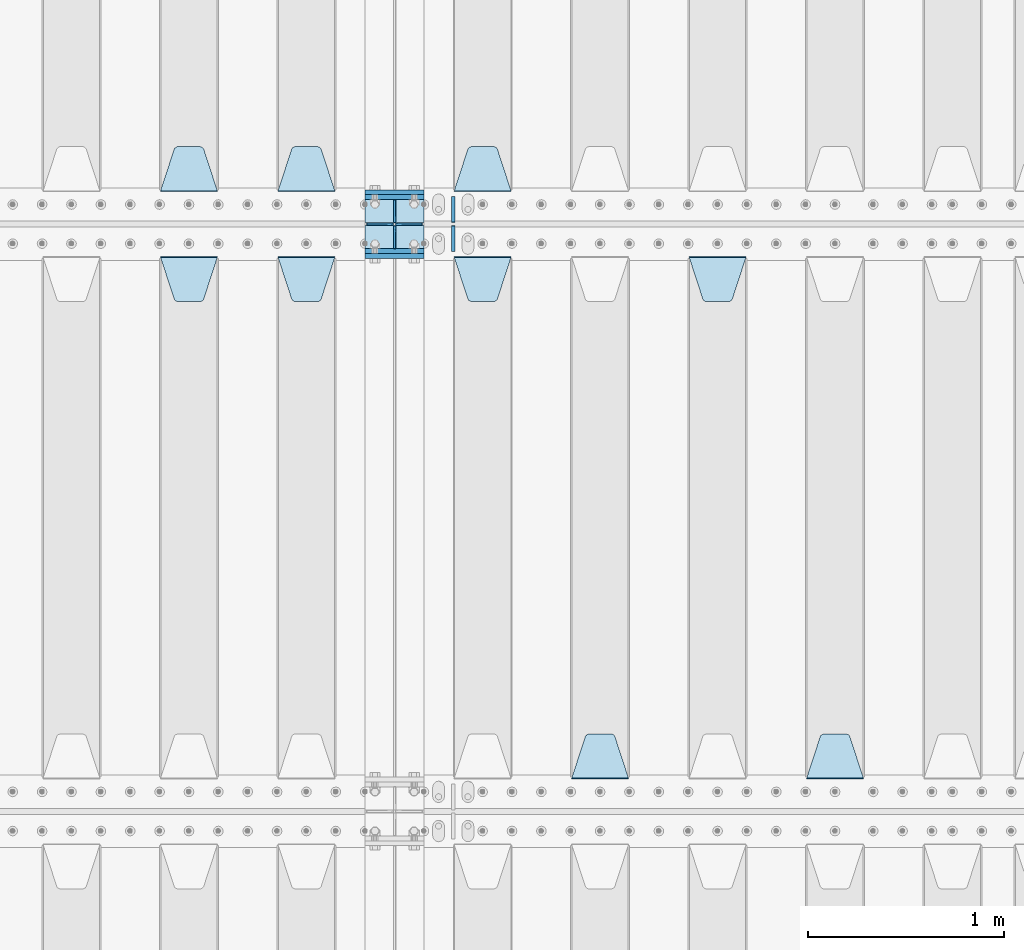
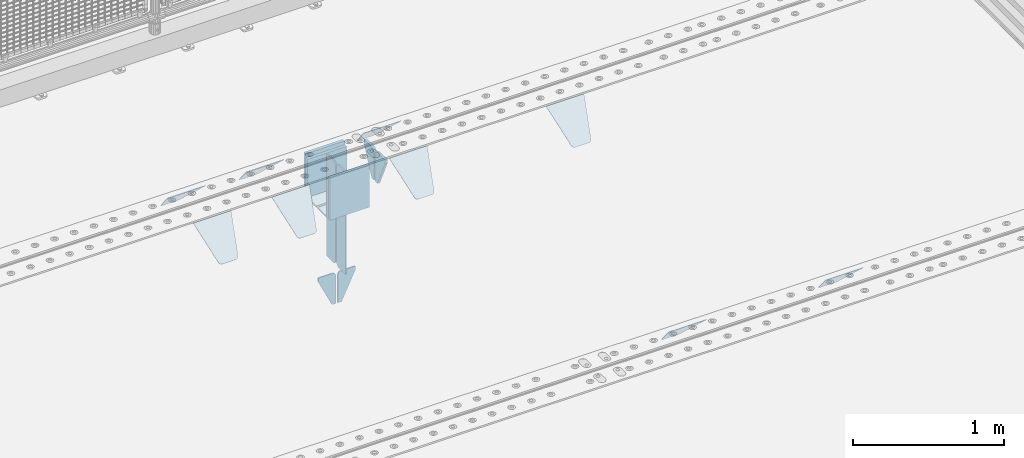
# One storey, part 210 of 247: 23 plates.
"""IFC2X3 building model written with IfcOpenShell, lengths in millimetres."""

import ifcopenshell
import ifcopenshell.guid

model = None  # the IFC model being written
_history = None  # IfcOwnerHistory: only IFC2X3 demands one
_inside = {}  # id of a spatial element -> (the spatial element, [elements in it])
_under = {}  # id of a project, library or spatial element -> (it, [spatial elements below it])
_declared = {}  # id of a project -> (the project, [libraries it declares])
_typed = {}  # id of a type object -> (the type object, [elements of that type])
_made_of = {}  # id of a material, layer set ... -> (it, [elements and type objects made of it])


def new_model(schema):
    """Start an empty IFC model of exactly this schema.

    Asked for "IFC4X3", IfcOpenShell would pick the latest addendum, in which some entities
    have other attributes; the version numbers below select the first issue.
    IFC2X3 requires an IfcOwnerHistory on every rooted entity: one is made here for all.
    """
    global model, _history
    if schema == "IFC4X3":
        model = ifcopenshell.file(schema_version=(4, 3, 0, 0))
    else:
        model = ifcopenshell.file(schema=schema)
    _inside.clear()
    _under.clear()
    _declared.clear()
    _typed.clear()
    _made_of.clear()
    _history = None
    if model.schema == "IFC2X3":
        org = make("IfcOrganization", Name="unknown")
        user = make(
            "IfcPersonAndOrganization",
            ThePerson=make("IfcPerson", FamilyName="unknown"),
            TheOrganization=org,
        )
        app = make(
            "IfcApplication",
            ApplicationDeveloper=org,
            Version="unknown",
            ApplicationFullName="unknown",
            ApplicationIdentifier="unknown",
        )
        _history = make(
            "IfcOwnerHistory",
            OwningUser=user,
            OwningApplication=app,
            ChangeAction="ADDED",
            CreationDate=0,
        )
    return model


def make(cls, **values):
    """One entity of the class cls with the attributes given. An attribute that is None is left unset."""
    return model.create_entity(
        cls, **{name: value for name, value in values.items() if value is not None}
    )


def rooted(cls, **values):
    """An entity with a GlobalId (a new one), such as an element, a storey or a relation."""
    return make(cls, GlobalId=ifcopenshell.guid.new(), OwnerHistory=_history, **values)


def si_unit(unit_type, name, prefix=None):
    """IfcSIUnit, for example si_unit("LENGTHUNIT", "METRE", prefix="MILLI")."""
    return make("IfcSIUnit", UnitType=unit_type, Prefix=prefix, Name=name)


def assignment(units):
    """IfcUnitAssignment: the units of a project."""
    return None if units is None else make("IfcUnitAssignment", Units=units)


def point(xyz):
    """IfcCartesianPoint."""
    return None if xyz is None else make("IfcCartesianPoint", Coordinates=xyz)


def direction(xyz):
    """IfcDirection."""
    return None if xyz is None else make("IfcDirection", DirectionRatios=xyz)


def frame(location, z_axis=None, x_axis=None):
    """IfcAxis2Placement3D, a coordinate frame: its origin and axes. An axis left out is left unset."""
    return make(
        "IfcAxis2Placement3D",
        Location=point(location),
        Axis=direction(z_axis),
        RefDirection=direction(x_axis),
    )


def origin_with_axes():
    """The frame at (0, 0, 0) with the z axis (0, 0, 1) and the x axis (1, 0, 0) written out."""
    return frame((0.0, 0.0, 0.0), z_axis=(0.0, 0.0, 1.0), x_axis=(1.0, 0.0, 0.0))


def place(relative_to, where):
    """IfcLocalPlacement: puts the frame where relative to a parent placement (None: the world)."""
    return make(
        "IfcLocalPlacement", PlacementRelTo=relative_to, RelativePlacement=where
    )


def context(
    kind, dimensions, precision=None, world=None, true_north=None, identifier=None
):
    """IfcGeometricRepresentationContext, for example the 3D "Model" context."""
    return make(
        "IfcGeometricRepresentationContext",
        ContextIdentifier=identifier,
        ContextType=kind,
        CoordinateSpaceDimension=dimensions,
        Precision=precision,
        WorldCoordinateSystem=world,
        TrueNorth=true_north,
    )


def subcontext(parent, identifier, kind, view, scale=None):
    """IfcGeometricRepresentationSubContext, for example "Body" below "Model"."""
    return make(
        "IfcGeometricRepresentationSubContext",
        ContextIdentifier=identifier,
        ContextType=kind,
        ParentContext=parent,
        TargetScale=scale,
        TargetView=view,
    )


def project(units=None, contexts=None):
    """IfcProject with its units and contexts."""
    return rooted(
        "IfcProject",
        Name="project",
        RepresentationContexts=contexts,
        UnitsInContext=assignment(units),
    )


def spatial(cls, under=None, at=None, **own):
    """A site, building, storey or space (cls), placed at a placement, below another one or the project."""
    s = rooted(cls, ObjectPlacement=at, **own)
    if under is not None:
        _under.setdefault(under.id(), (under, []))[1].append(s)
    return s


def faces_of(points, faces, orient=None, outer=None):
    """IfcFace entities. A face is a list of loops; a loop is a list of indices into points, from 0.

    orient and outer hold one flag for each loop. By default every Orientation is true, the
    first loop of a face is its IfcFaceOuterBound and the others are IfcFaceBound.
    """
    made = []
    for i, loops in enumerate(faces):
        bounds = []
        for j, loop in enumerate(loops):
            is_outer = j == 0 if outer is None else outer[i][j]
            bounds.append(
                make(
                    "IfcFaceOuterBound" if is_outer else "IfcFaceBound",
                    Bound=make("IfcPolyLoop", Polygon=[points[k] for k in loop]),
                    Orientation=True if orient is None else orient[i][j],
                )
            )
        made.append(make("IfcFace", Bounds=bounds))
    return made


def faceted_brep(points, faces, orient=None, outer=None, voids=None):
    """IfcFacetedBrep: a solid bounded by flat faces; with voids (closed shells), ...WithVoids."""
    shared = [point(p) for p in points]
    hull = make("IfcClosedShell", CfsFaces=faces_of(shared, faces, orient, outer))
    if voids is None:
        return make("IfcFacetedBrep", Outer=hull)
    return make(
        "IfcFacetedBrepWithVoids",
        Outer=hull,
        Voids=[
            make(cls, CfsFaces=faces_of(shared, fs, o, b)) for cls, fs, o, b in voids
        ],
    )


def shape(context_of_items, identifier, shape_type, items):
    """IfcShapeRepresentation: the items that make up one representation, for example the "Body"."""
    return make(
        "IfcShapeRepresentation",
        ContextOfItems=context_of_items,
        RepresentationIdentifier=identifier,
        RepresentationType=shape_type,
        Items=items,
    )


def material(Name=None, Category=None):
    """IfcMaterial."""
    return make("IfcMaterial", Name=Name, Category=Category)


def made_of(thing, what):
    """Note that an element or type object is made of a material, layer set ...; save() writes the relation."""
    if what is not None:
        _made_of.setdefault(what.id(), (what, []))[1].append(thing)
    return thing


def type_object(cls, material=None, **own):
    """A type object (cls), such as IfcWallType, which elements share."""
    return made_of(rooted(cls, **own), material)


def element(
    cls,
    number,
    at=None,
    inside=None,
    cuts=None,
    type_object=None,
    material=None,
    context=None,
    identifier="Body",
    shape_type=None,
    held_by="IfcProductDefinitionShape",
    body=None,
    shapes=None,
    **own,
):
    """One element of the class cls, such as IfcWall. Its Tag is "e" and its number.

    at: its placement. inside: the storey or other place that contains it. cuts: it is an
    opening in that element (IfcRelVoidsElement). A single representation is given by context,
    identifier, shape_type and body (its items); several are given by shapes. held_by: the class
    of the entity that holds the representations. save() writes the other relations.
    """
    e = rooted(cls, Tag="e%d" % number, ObjectPlacement=at, **own)
    if body is not None:
        shapes = [shape(context, identifier, shape_type, body)]
    if shapes is not None:
        e.Representation = make(held_by, Representations=shapes)
    if inside is not None:
        _inside.setdefault(inside.id(), (inside, []))[1].append(e)
    if cuts is not None:
        rooted(
            "IfcRelVoidsElement", RelatingBuildingElement=cuts, RelatedOpeningElement=e
        )
    if type_object is not None:
        _typed.setdefault(type_object.id(), (type_object, []))[1].append(e)
    return made_of(e, material)


def aggregate(whole, parts):
    """IfcRelAggregates: a whole, such as a stair, and the parts it consists of."""
    return rooted("IfcRelAggregates", RelatingObject=whole, RelatedObjects=parts)


def save(model, path):
    """Write the relations noted so far, then the file.

    IfcRelAggregates (storeys below a building ...), IfcRelContainedInSpatialStructure (elements
    in a storey), IfcRelDefinesByType, IfcRelAssociatesMaterial and IfcRelDeclares: one each for
    every whole, place, type object, material and project.
    """
    for whole, parts in _under.values():
        aggregate(whole, parts)
    for where, things in _inside.values():
        rooted(
            "IfcRelContainedInSpatialStructure",
            RelatedElements=things,
            RelatingStructure=where,
        )
    for kind, things in _typed.values():
        rooted("IfcRelDefinesByType", RelatedObjects=things, RelatingType=kind)
    for what, things in _made_of.values():
        rooted("IfcRelAssociatesMaterial", RelatedObjects=things, RelatingMaterial=what)
    for by, libraries in _declared.values():
        rooted("IfcRelDeclares", RelatingContext=by, RelatedDefinitions=libraries)
    model.write(path)


model = new_model("IFC2X3")

# Units and contexts
model_context = context("Model", 3, precision=1e-05, world=origin_with_axes())
body_context = subcontext(model_context, "Body", "Model", "MODEL_VIEW")
ifc_project = project(units=[si_unit("LENGTHUNIT", "METRE", prefix="MILLI"), si_unit("AREAUNIT", "SQUARE_METRE"), si_unit("VOLUMEUNIT", "CUBIC_METRE"), si_unit("MASSUNIT", "GRAM", prefix="KILO"), si_unit("TIMEUNIT", "SECOND"), si_unit("PLANEANGLEUNIT", "RADIAN"), si_unit("SOLIDANGLEUNIT", "STERADIAN"), si_unit("THERMODYNAMICTEMPERATUREUNIT", "DEGREE_CELSIUS"), si_unit("LUMINOUSINTENSITYUNIT", "LUMEN")], contexts=[model_context])

# Site, building, storey
site_placement = place(None, origin_with_axes())
site = spatial("IfcSite", under=ifc_project, at=site_placement, CompositionType="ELEMENT")
building_placement = place(site_placement, origin_with_axes())
building = spatial("IfcBuilding", under=site, at=building_placement, Name="Standard", CompositionType="ELEMENT")
storey_placement = place(building_placement, origin_with_axes())
storey = spatial("IfcBuildingStorey", under=building, at=storey_placement, Name="Undefined", CompositionType="ELEMENT", Elevation=0.0)

# Plates
ifc_material = material(Name="STEEL/S355N")
plate_type_1 = type_object("IfcPlateType", PredefinedType="NOTDEFINED")
for number, where, z_axis, x_axis in (
    (1, (12100.0, 6162.5, -340.000000000044), (0.0, 0.0, 1.0), (1.0, 0.0, 0.0)),
    (2, (12100.0, 5837.5, -340.000000000044), (0.0, 0.0, 1.0), (1.0, 0.0, 0.0)),
):
    element("IfcPlate", number, at=place(storey_placement, frame(where, z_axis=z_axis, x_axis=x_axis)), inside=storey, type_object=plate_type_1, material=ifc_material, context=body_context, shape_type="Brep", body=[
        faceted_brep([(0.0, -12.5, 0.0), (0.0, -12.5, 340.0), (0.0, 12.5, 340.0), (0.0, 12.5, 0.0), (300.0, -12.5, 340.0), (300.0, 12.5, 340.0), (300.0, -12.5, 0.0), (300.0, 12.5, 0.0)], [[[0, 1, 2, 3]], [[1, 4, 5, 2]], [[4, 6, 7, 5]], [[6, 0, 3, 7]], [[5, 7, 3, 2]], [[6, 4, 1, 0]]]),
    ])
for number, where, z_axis, x_axis in (
    (3, (12100.0, 6137.5, -340.0), (0.0, 0.0, 1.0), (1.0, 0.0, 0.0)),
    (4, (12100.0, 5862.5, -340.0), (0.0, 0.0, 1.0), (1.0, 0.0, 0.0)),
):
    element("IfcPlate", number, at=place(storey_placement, frame(where, z_axis=z_axis, x_axis=x_axis)), inside=storey, type_object=plate_type_1, material=ifc_material, context=body_context, shape_type="Brep", body=[
        faceted_brep([(0.0, -12.5, 0.0), (0.0, -12.5, 310.0), (0.0, 12.5, 310.0), (0.0, 12.5, 0.0), (300.0, -12.5, 310.0), (300.0, 12.5, 310.0), (300.0, -12.5, 0.0), (300.0, 12.5, 0.0)], [[[0, 1, 2, 3]], [[1, 4, 5, 2]], [[4, 6, 7, 5]], [[6, 0, 3, 7]], [[5, 7, 3, 2]], [[6, 4, 1, 0]]]),
    ])
plate_type_2 = type_object("IfcPlateType", PredefinedType="NOTDEFINED")
for number, where, z_axis, x_axis in (
    (5, (12100.0, 5992.0, -343.0), (0.0, -0.999999999999548, -9.5100000000016e-07), (1.0, 0.0, 0.0)),
    (6, (12100.0, 6008.0, -343.0), (0.0, 1.0, 0.0), (1.0, 0.0, 0.0)),
):
    element("IfcPlate", number, at=place(storey_placement, frame(where, z_axis=z_axis, x_axis=x_axis)), inside=storey, type_object=plate_type_2, material=ifc_material, context=body_context, shape_type="Brep", body=[
        faceted_brep([(0.0, -7.0, 0.0), (0.0, -7.0, 117.0), (0.0, 7.0, 117.0), (0.0, 7.0, 0.0), (300.0, -7.0, 117.0), (300.0, 7.0, 117.0), (300.0, -7.0, 0.0), (300.0, 7.0, 0.0)], [[[0, 1, 2, 3]], [[1, 4, 5, 2]], [[4, 6, 7, 5]], [[6, 0, 3, 7]], [[5, 7, 3, 2]], [[6, 4, 1, 0]]]),
    ])
plate_type_3 = type_object("IfcPlateType", PredefinedType="NOTDEFINED")
for number, where, z_axis, x_axis in (
    (7, (12250.0, 5992.0, -350.0), (0.0, 0.0, -1.0), (0.0, -0.999999999999548, -9.5100000000016e-07)),
    (8, (12250.0, 6008.0, -350.0), (0.0, 0.0, -1.0), (0.0, 1.0, 0.0)),
):
    element("IfcPlate", number, at=place(storey_placement, frame(where, z_axis=z_axis, x_axis=x_axis)), inside=storey, type_object=plate_type_3, material=ifc_material, context=body_context, shape_type="Brep", body=[
        faceted_brep([(9.04219632502645e-09, -5.00000000143385, -2.89173840428703e-09), (0.0, -5.0, 480.0), (0.0, 5.0, 480.0), (7.66340235713869e-09, 4.99999999856618, -2.89173840428703e-09), (0.455767409633609, -5.0, 485.209445330008), (0.455767409633609, 5.0, 485.209445330008), (1.80922137642256, -5.0, 490.26060429977), (1.80922137642256, 5.0, 490.26060429977), (4.01923788646673, -5.0, 495.0), (4.01923788646673, 5.0, 495.0), (7.01866670643085, -5.0, 499.283628290596), (7.01866670643085, 5.0, 499.283628290596), (10.716371709404, -5.0, 502.981333293569), (10.716371709404, 5.0, 502.981333293569), (15.0, -5.0, 505.980762113533), (15.0, 5.0, 505.980762113533), (19.73939570023, -5.0, 508.190778623577), (19.73939570023, 5.0, 508.190778623577), (24.7905546699922, -5.0, 509.544232590366), (24.7905546699922, 5.0, 509.544232590366), (30.0, -5.0, 510.0), (30.0, 5.0, 510.0), (117.0, -5.0, 510.0), (117.0, 5.0, 510.0), (117.0, -5.0, 0.0), (117.0, 5.0, 0.0)], [[[0, 1, 2, 3]], [[1, 4, 5, 2]], [[4, 6, 7, 5]], [[6, 8, 9, 7]], [[8, 10, 11, 9]], [[10, 12, 13, 11]], [[12, 14, 15, 13]], [[14, 16, 17, 15]], [[16, 18, 19, 17]], [[18, 20, 21, 19]], [[20, 22, 23, 21]], [[22, 24, 25, 23]], [[24, 0, 3, 25]], [[5, 7, 9, 11, 13, 15, 17, 19, 21, 23, 25, 3, 2]], [[24, 22, 20, 18, 16, 14, 12, 10, 8, 6, 4, 1, 0]]]),
    ])
for number, where, z_axis, x_axis in (
    (9, (12250.0, 6008.0, -30.0), (0.0, 0.0, -1.0), (0.0, 1.0, 0.0)),
    (10, (12250.0, 5992.0, -30.0), (0.0, 0.0, -1.0), (0.0, -0.999999999999548, -9.5100000000016e-07)),
):
    element("IfcPlate", number, at=place(storey_placement, frame(where, z_axis=z_axis, x_axis=x_axis)), inside=storey, type_object=plate_type_3, material=ifc_material, context=body_context, shape_type="Brep", body=[
        faceted_brep([(0.0, -5.0, 30.0), (0.0, -5.0, 306.0), (0.0, 5.0, 306.0), (0.0, 5.0, 30.0), (117.0, -5.0, 306.0), (117.0, 5.0, 306.0), (117.0, -5.0, 0.0), (117.0, 5.0, 0.0), (30.0, -5.0, 0.0), (30.0, 5.0, 0.0), (24.7905546699922, -5.0, 0.455767409633758), (24.7905546699922, 5.0, 0.455767409633758), (19.73939570023, -5.0, 1.80922137642275), (19.73939570023, 5.0, 1.80922137642275), (15.0, -5.0, 4.01923788646684), (15.0, 5.0, 4.01923788646684), (10.716371709404, -5.0, 7.01866670643066), (10.716371709404, 5.0, 7.01866670643066), (7.01866670643085, -5.0, 10.7163717094038), (7.01866670643085, 5.0, 10.7163717094038), (4.01923788646673, -5.0, 15.0), (4.01923788646673, 5.0, 15.0), (1.80922137642256, -5.0, 19.7393957002299), (1.80922137642256, 5.0, 19.7393957002299), (0.455767409633609, -5.0, 24.7905546699921), (0.455767409633609, 5.0, 24.7905546699921)], [[[0, 1, 2, 3]], [[1, 4, 5, 2]], [[4, 6, 7, 5]], [[6, 8, 9, 7]], [[8, 10, 11, 9]], [[10, 12, 13, 11]], [[12, 14, 15, 13]], [[14, 16, 17, 15]], [[16, 18, 19, 17]], [[18, 20, 21, 19]], [[20, 22, 23, 21]], [[22, 24, 25, 23]], [[24, 0, 3, 25]], [[5, 7, 9, 11, 13, 15, 17, 19, 21, 23, 25, 3, 2]], [[24, 22, 20, 18, 16, 14, 12, 10, 8, 6, 4, 1, 0]]]),
    ])
plate_type_4 = type_object("IfcPlateType", PredefinedType="NOTDEFINED")
for number, where, z_axis, x_axis in (
    (11, (12243.5000000115, 5999.99999998465, -915.000018222569), (0.0, 0.0, -1.0), (-1.0, 0.0, 0.0)),
    (12, (12256.5000000115, 5999.99999998464, -915.000018222569), (0.0, 0.0, -1.0), (1.0, 0.0, 0.0)),
):
    element("IfcPlate", number, at=place(storey_placement, frame(where, z_axis=z_axis, x_axis=x_axis)), inside=storey, type_object=plate_type_4, material=ifc_material, context=body_context, shape_type="Brep", body=[
        faceted_brep([(0.0, -5.0, 27.0), (0.0, -5.0, 250.0), (0.0, 5.0, 250.0), (0.0, 5.0, 27.0), (30.0, -5.0, 250.0), (30.0, 5.0, 250.0), (135.0, -5.0, 30.0), (135.0, 5.0, 30.0), (135.0, -5.0, 0.0), (135.0, 5.0, 0.0), (27.0, -5.0, 0.0), (27.0, 5.0, 0.0), (22.3114992029932, -5.0, 0.410190668670339), (22.3114992029932, 5.0, 0.410190668670339), (17.7654561302061, -5.0, 1.62829923878041), (17.7654561302061, 5.0, 1.62829923878041), (13.5, -5.0, 3.61731409782021), (13.5, 5.0, 3.61731409782021), (9.64473453846404, -5.0, 6.31680003578765), (9.64473453846404, 5.0, 6.31680003578765), (6.31680003578731, -5.0, 9.64473453846347), (6.31680003578731, 5.0, 9.64473453846347), (3.61731409782078, -5.0, 13.5), (3.61731409782078, 5.0, 13.5), (1.62829923878053, -5.0, 17.765456130207), (1.62829923878053, 5.0, 17.765456130207), (0.410190668670111, -5.0, 22.3114992029929), (0.410190668670111, 5.0, 22.3114992029929)], [[[0, 1, 2, 3]], [[1, 4, 5, 2]], [[4, 6, 7, 5]], [[6, 8, 9, 7]], [[8, 10, 11, 9]], [[10, 12, 13, 11]], [[12, 14, 15, 13]], [[14, 16, 17, 15]], [[16, 18, 19, 17]], [[18, 20, 21, 19]], [[20, 22, 23, 21]], [[22, 24, 25, 23]], [[24, 26, 27, 25]], [[26, 0, 3, 27]], [[5, 7, 9, 11, 13, 15, 17, 19, 21, 23, 25, 27, 3, 2]], [[26, 24, 22, 20, 18, 16, 14, 12, 10, 8, 6, 4, 1, 0]]]),
    ])
plate_type_5 = type_object("IfcPlateType", PredefinedType="NOTDEFINED")
plate_1_placement = place(storey_placement, frame((14645.0, 3168.23223304703, -1.76776695296758), z_axis=(0.0, 0.707106781186548, -0.707106781186547), x_axis=(-1.0, 0.0, 0.0)))
element("IfcPlate", 13, at=plate_1_placement, inside=storey, type_object=plate_type_5, material=ifc_material, context=body_context, shape_type="Brep", body=[
    faceted_brep([(0.0, -2.49999999999909, 0.0), (69.345504679477, -2.5, 300.17173142483), (69.345504679477, 2.50000000000091, 300.171731424831), (0.0, 2.5, -9.09494701772928e-13), (70.9274061199576, -2.5, 304.897442415399), (70.9274061199576, 2.50000000000091, 304.8974424154), (73.3818627772307, -2.49999999999909, 309.234538108527), (73.3818627772307, 2.5, 309.234538108526), (76.6187032999551, -2.5, 313.023683126102), (76.6187032999551, 2.50000000000091, 313.023683126102), (80.5190132704993, -2.49999999999909, 316.125672595371), (80.5190132704993, 2.50000000000091, 316.125672595372), (84.9395038596849, -2.49999999999909, 318.426546230476), (84.9395038596849, 2.5, 318.426546230475), (89.7177759439219, -2.5, 319.841774983274), (89.7177759439219, 2.50000000000091, 319.841774983275), (94.678286292652, -2.5, 320.319366455077), (94.678286292652, 2.50000000000091, 320.319366455077), (195.321713707348, -2.5, 320.319366455077), (195.321713707348, 2.50000000000091, 320.319366455077), (200.282224056078, -2.5, 319.841774983274), (200.282224056078, 2.50000000000091, 319.841774983275), (205.060496140315, -2.5, 318.426546230475), (205.060496140315, 2.5, 318.426546230474), (209.480986729501, -2.49999999999818, 316.12567259537), (209.480986729501, 2.50000000000091, 316.12567259537), (213.381296700045, -2.5, 313.023683126101), (213.381296700045, 2.50000000000091, 313.023683126101), (216.618137222769, -2.5, 309.234538108525), (216.618137222769, 2.5, 309.234538108525), (219.072593880042, -2.49999999999909, 304.897442415398), (219.072593880042, 2.5, 304.897442415398), (220.654495320523, -2.5, 300.17173142483), (220.654495320523, 2.50000000000091, 300.171731424831), (290.0, -2.49999999999909, 0.0), (290.0, 2.5, -9.09494701772928e-13)], [[[0, 1, 2, 3]], [[1, 4, 5, 2]], [[4, 6, 7, 5]], [[6, 8, 9, 7]], [[8, 10, 11, 9]], [[10, 12, 13, 11]], [[12, 14, 15, 13]], [[14, 16, 17, 15]], [[16, 18, 19, 17]], [[18, 20, 21, 19]], [[20, 22, 23, 21]], [[22, 24, 25, 23]], [[24, 26, 27, 25]], [[26, 28, 29, 27]], [[28, 30, 31, 29]], [[30, 32, 33, 31]], [[32, 34, 35, 33]], [[34, 0, 3, 35]], [[5, 7, 9, 11, 13, 15, 17, 19, 21, 23, 25, 27, 29, 31, 33, 35, 3, 2]], [[34, 32, 30, 28, 26, 24, 22, 20, 18, 16, 14, 12, 10, 8, 6, 4, 1, 0]]]),
])
plate_2_placement = place(storey_placement, frame((13755.0, 5831.76776695594, -1.767766952965), z_axis=(0.0, -0.707106781186548, -0.707106781186547), x_axis=(1.0, 0.0, 0.0)))
element("IfcPlate", 14, at=plate_2_placement, inside=storey, type_object=plate_type_5, material=ifc_material, context=body_context, shape_type="Brep", body=[
    faceted_brep([(0.0, -2.49999999999909, 0.0), (69.345504679477, -2.5, 300.17173142483), (69.345504679477, 2.50000000000091, 300.171731424831), (0.0, 2.5, -9.09494701772928e-13), (70.9274061199576, -2.5, 304.897442415399), (70.9274061199576, 2.50000000000091, 304.8974424154), (73.3818627772307, -2.49999999999909, 309.234538108527), (73.3818627772307, 2.5, 309.234538108526), (76.6187032999551, -2.5, 313.023683126102), (76.6187032999551, 2.50000000000091, 313.023683126102), (80.5190132704993, -2.49999999999909, 316.125672595371), (80.5190132704993, 2.50000000000091, 316.125672595372), (84.9395038596849, -2.49999999999909, 318.426546230476), (84.9395038596849, 2.5, 318.426546230475), (89.7177759439219, -2.5, 319.841774983274), (89.7177759439219, 2.50000000000091, 319.841774983275), (94.678286292652, -2.5, 320.319366455077), (94.678286292652, 2.50000000000091, 320.319366455077), (195.321713707348, -2.5, 320.319366455077), (195.321713707348, 2.50000000000091, 320.319366455077), (200.282224056078, -2.5, 319.841774983274), (200.282224056078, 2.50000000000091, 319.841774983275), (205.060496140315, -2.5, 318.426546230475), (205.060496140315, 2.5, 318.426546230474), (209.480986729501, -2.49999999999818, 316.12567259537), (209.480986729501, 2.50000000000091, 316.12567259537), (213.381296700045, -2.5, 313.023683126101), (213.381296700045, 2.50000000000091, 313.023683126101), (216.618137222769, -2.5, 309.234538108525), (216.618137222769, 2.5, 309.234538108525), (219.072593880042, -2.49999999999909, 304.897442415398), (219.072593880042, 2.5, 304.897442415398), (220.654495320523, -2.5, 300.17173142483), (220.654495320523, 2.50000000000091, 300.171731424831), (290.0, -2.49999999999909, 0.0), (290.0, 2.5, -9.09494701772928e-13)], [[[0, 1, 2, 3]], [[1, 4, 5, 2]], [[4, 6, 7, 5]], [[6, 8, 9, 7]], [[8, 10, 11, 9]], [[10, 12, 13, 11]], [[12, 14, 15, 13]], [[14, 16, 17, 15]], [[16, 18, 19, 17]], [[18, 20, 21, 19]], [[20, 22, 23, 21]], [[22, 24, 25, 23]], [[24, 26, 27, 25]], [[26, 28, 29, 27]], [[28, 30, 31, 29]], [[30, 32, 33, 31]], [[32, 34, 35, 33]], [[34, 0, 3, 35]], [[5, 7, 9, 11, 13, 15, 17, 19, 21, 23, 25, 27, 29, 31, 33, 35, 3, 2]], [[34, 32, 30, 28, 26, 24, 22, 20, 18, 16, 14, 12, 10, 8, 6, 4, 1, 0]]]),
])
plate_3_placement = place(storey_placement, frame((13445.0, 3168.23223304703, -1.76776695296758), z_axis=(0.0, 0.707106781186548, -0.707106781186547), x_axis=(-1.0, 0.0, 0.0)))
element("IfcPlate", 15, at=plate_3_placement, inside=storey, type_object=plate_type_5, material=ifc_material, context=body_context, shape_type="Brep", body=[
    faceted_brep([(0.0, -2.49999999999909, 0.0), (69.345504679477, -2.5, 300.17173142483), (69.345504679477, 2.50000000000091, 300.171731424831), (0.0, 2.5, -9.09494701772928e-13), (70.9274061199576, -2.5, 304.897442415399), (70.9274061199576, 2.50000000000091, 304.8974424154), (73.3818627772307, -2.49999999999909, 309.234538108527), (73.3818627772307, 2.5, 309.234538108526), (76.6187032999551, -2.5, 313.023683126102), (76.6187032999551, 2.50000000000091, 313.023683126102), (80.5190132704993, -2.49999999999909, 316.125672595371), (80.5190132704993, 2.50000000000091, 316.125672595372), (84.9395038596849, -2.49999999999909, 318.426546230476), (84.9395038596849, 2.5, 318.426546230475), (89.7177759439219, -2.5, 319.841774983274), (89.7177759439219, 2.50000000000091, 319.841774983275), (94.678286292652, -2.5, 320.319366455077), (94.678286292652, 2.50000000000091, 320.319366455077), (195.321713707348, -2.5, 320.319366455077), (195.321713707348, 2.50000000000091, 320.319366455077), (200.282224056078, -2.5, 319.841774983274), (200.282224056078, 2.50000000000091, 319.841774983275), (205.060496140315, -2.5, 318.426546230475), (205.060496140315, 2.5, 318.426546230474), (209.480986729501, -2.49999999999818, 316.12567259537), (209.480986729501, 2.50000000000091, 316.12567259537), (213.381296700045, -2.5, 313.023683126101), (213.381296700045, 2.50000000000091, 313.023683126101), (216.618137222769, -2.5, 309.234538108525), (216.618137222769, 2.5, 309.234538108525), (219.072593880042, -2.49999999999909, 304.897442415398), (219.072593880042, 2.5, 304.897442415398), (220.654495320523, -2.5, 300.17173142483), (220.654495320523, 2.50000000000091, 300.171731424831), (290.0, -2.49999999999909, 0.0), (290.0, 2.5, -9.09494701772928e-13)], [[[0, 1, 2, 3]], [[1, 4, 5, 2]], [[4, 6, 7, 5]], [[6, 8, 9, 7]], [[8, 10, 11, 9]], [[10, 12, 13, 11]], [[12, 14, 15, 13]], [[14, 16, 17, 15]], [[16, 18, 19, 17]], [[18, 20, 21, 19]], [[20, 22, 23, 21]], [[22, 24, 25, 23]], [[24, 26, 27, 25]], [[26, 28, 29, 27]], [[28, 30, 31, 29]], [[30, 32, 33, 31]], [[32, 34, 35, 33]], [[34, 0, 3, 35]], [[5, 7, 9, 11, 13, 15, 17, 19, 21, 23, 25, 27, 29, 31, 33, 35, 3, 2]], [[34, 32, 30, 28, 26, 24, 22, 20, 18, 16, 14, 12, 10, 8, 6, 4, 1, 0]]]),
])
plate_4_placement = place(storey_placement, frame((12555.0, 5831.76776695594, -1.767766952965), z_axis=(0.0, -0.707106781186548, -0.707106781186547), x_axis=(1.0, 0.0, 0.0)))
element("IfcPlate", 16, at=plate_4_placement, inside=storey, type_object=plate_type_5, material=ifc_material, context=body_context, shape_type="Brep", body=[
    faceted_brep([(0.0, -2.49999999999909, 0.0), (69.345504679477, -2.5, 300.17173142483), (69.345504679477, 2.50000000000091, 300.171731424831), (0.0, 2.5, -9.09494701772928e-13), (70.9274061199576, -2.5, 304.897442415399), (70.9274061199576, 2.50000000000091, 304.8974424154), (73.3818627772307, -2.49999999999909, 309.234538108527), (73.3818627772307, 2.5, 309.234538108526), (76.6187032999551, -2.5, 313.023683126102), (76.6187032999551, 2.50000000000091, 313.023683126102), (80.5190132704993, -2.49999999999909, 316.125672595371), (80.5190132704993, 2.50000000000091, 316.125672595372), (84.9395038596849, -2.49999999999909, 318.426546230476), (84.9395038596849, 2.5, 318.426546230475), (89.7177759439219, -2.5, 319.841774983274), (89.7177759439219, 2.50000000000091, 319.841774983275), (94.678286292652, -2.5, 320.319366455077), (94.678286292652, 2.50000000000091, 320.319366455077), (195.321713707348, -2.5, 320.319366455077), (195.321713707348, 2.50000000000091, 320.319366455077), (200.282224056078, -2.5, 319.841774983274), (200.282224056078, 2.50000000000091, 319.841774983275), (205.060496140315, -2.5, 318.426546230475), (205.060496140315, 2.5, 318.426546230474), (209.480986729501, -2.49999999999818, 316.12567259537), (209.480986729501, 2.50000000000091, 316.12567259537), (213.381296700045, -2.5, 313.023683126101), (213.381296700045, 2.50000000000091, 313.023683126101), (216.618137222769, -2.5, 309.234538108525), (216.618137222769, 2.5, 309.234538108525), (219.072593880042, -2.49999999999909, 304.897442415398), (219.072593880042, 2.5, 304.897442415398), (220.654495320523, -2.5, 300.17173142483), (220.654495320523, 2.50000000000091, 300.171731424831), (290.0, -2.49999999999909, 0.0), (290.0, 2.5, -9.09494701772928e-13)], [[[0, 1, 2, 3]], [[1, 4, 5, 2]], [[4, 6, 7, 5]], [[6, 8, 9, 7]], [[8, 10, 11, 9]], [[10, 12, 13, 11]], [[12, 14, 15, 13]], [[14, 16, 17, 15]], [[16, 18, 19, 17]], [[18, 20, 21, 19]], [[20, 22, 23, 21]], [[22, 24, 25, 23]], [[24, 26, 27, 25]], [[26, 28, 29, 27]], [[28, 30, 31, 29]], [[30, 32, 33, 31]], [[32, 34, 35, 33]], [[34, 0, 3, 35]], [[5, 7, 9, 11, 13, 15, 17, 19, 21, 23, 25, 27, 29, 31, 33, 35, 3, 2]], [[34, 32, 30, 28, 26, 24, 22, 20, 18, 16, 14, 12, 10, 8, 6, 4, 1, 0]]]),
])
plate_5_placement = place(storey_placement, frame((11655.0, 5831.76776695594, -1.767766952965), z_axis=(0.0, -0.707106781186548, -0.707106781186547), x_axis=(1.0, 0.0, 0.0)))
element("IfcPlate", 17, at=plate_5_placement, inside=storey, type_object=plate_type_5, material=ifc_material, context=body_context, shape_type="Brep", body=[
    faceted_brep([(0.0, -2.49999999999909, 0.0), (69.345504679477, -2.5, 300.17173142483), (69.345504679477, 2.50000000000091, 300.171731424831), (0.0, 2.5, -9.09494701772928e-13), (70.9274061199576, -2.5, 304.897442415399), (70.9274061199576, 2.50000000000091, 304.8974424154), (73.3818627772307, -2.49999999999909, 309.234538108527), (73.3818627772307, 2.5, 309.234538108526), (76.6187032999551, -2.5, 313.023683126102), (76.6187032999551, 2.50000000000091, 313.023683126102), (80.5190132704993, -2.49999999999909, 316.125672595371), (80.5190132704993, 2.50000000000091, 316.125672595372), (84.9395038596849, -2.49999999999909, 318.426546230476), (84.9395038596849, 2.5, 318.426546230475), (89.7177759439219, -2.5, 319.841774983274), (89.7177759439219, 2.50000000000091, 319.841774983275), (94.678286292652, -2.5, 320.319366455077), (94.678286292652, 2.50000000000091, 320.319366455077), (195.321713707348, -2.5, 320.319366455077), (195.321713707348, 2.50000000000091, 320.319366455077), (200.282224056078, -2.5, 319.841774983274), (200.282224056078, 2.50000000000091, 319.841774983275), (205.060496140315, -2.5, 318.426546230475), (205.060496140315, 2.5, 318.426546230474), (209.480986729501, -2.49999999999818, 316.12567259537), (209.480986729501, 2.50000000000091, 316.12567259537), (213.381296700045, -2.5, 313.023683126101), (213.381296700045, 2.50000000000091, 313.023683126101), (216.618137222769, -2.5, 309.234538108525), (216.618137222769, 2.5, 309.234538108525), (219.072593880042, -2.49999999999909, 304.897442415398), (219.072593880042, 2.5, 304.897442415398), (220.654495320523, -2.5, 300.17173142483), (220.654495320523, 2.50000000000091, 300.171731424831), (290.0, -2.49999999999909, 0.0), (290.0, 2.5, -9.09494701772928e-13)], [[[0, 1, 2, 3]], [[1, 4, 5, 2]], [[4, 6, 7, 5]], [[6, 8, 9, 7]], [[8, 10, 11, 9]], [[10, 12, 13, 11]], [[12, 14, 15, 13]], [[14, 16, 17, 15]], [[16, 18, 19, 17]], [[18, 20, 21, 19]], [[20, 22, 23, 21]], [[22, 24, 25, 23]], [[24, 26, 27, 25]], [[26, 28, 29, 27]], [[28, 30, 31, 29]], [[30, 32, 33, 31]], [[32, 34, 35, 33]], [[34, 0, 3, 35]], [[5, 7, 9, 11, 13, 15, 17, 19, 21, 23, 25, 27, 29, 31, 33, 35, 3, 2]], [[34, 32, 30, 28, 26, 24, 22, 20, 18, 16, 14, 12, 10, 8, 6, 4, 1, 0]]]),
])
plate_6_placement = place(storey_placement, frame((11055.0, 5831.76776695594, -1.767766952965), z_axis=(0.0, -0.707106781186548, -0.707106781186547), x_axis=(1.0, 0.0, 0.0)))
element("IfcPlate", 18, at=plate_6_placement, inside=storey, type_object=plate_type_5, material=ifc_material, context=body_context, shape_type="Brep", body=[
    faceted_brep([(0.0, -2.49999999999909, 0.0), (69.345504679477, -2.5, 300.17173142483), (69.345504679477, 2.50000000000091, 300.171731424831), (0.0, 2.5, -9.09494701772928e-13), (70.9274061199576, -2.5, 304.897442415399), (70.9274061199576, 2.50000000000091, 304.8974424154), (73.3818627772307, -2.49999999999909, 309.234538108527), (73.3818627772307, 2.5, 309.234538108526), (76.6187032999551, -2.5, 313.023683126102), (76.6187032999551, 2.50000000000091, 313.023683126102), (80.5190132704993, -2.49999999999909, 316.125672595371), (80.5190132704993, 2.50000000000091, 316.125672595372), (84.9395038596849, -2.49999999999909, 318.426546230476), (84.9395038596849, 2.5, 318.426546230475), (89.7177759439219, -2.5, 319.841774983274), (89.7177759439219, 2.50000000000091, 319.841774983275), (94.678286292652, -2.5, 320.319366455077), (94.678286292652, 2.50000000000091, 320.319366455077), (195.321713707348, -2.5, 320.319366455077), (195.321713707348, 2.50000000000091, 320.319366455077), (200.282224056078, -2.5, 319.841774983274), (200.282224056078, 2.50000000000091, 319.841774983275), (205.060496140315, -2.5, 318.426546230475), (205.060496140315, 2.5, 318.426546230474), (209.480986729501, -2.49999999999818, 316.12567259537), (209.480986729501, 2.50000000000091, 316.12567259537), (213.381296700045, -2.5, 313.023683126101), (213.381296700045, 2.50000000000091, 313.023683126101), (216.618137222769, -2.5, 309.234538108525), (216.618137222769, 2.5, 309.234538108525), (219.072593880042, -2.49999999999909, 304.897442415398), (219.072593880042, 2.5, 304.897442415398), (220.654495320523, -2.5, 300.17173142483), (220.654495320523, 2.50000000000091, 300.171731424831), (290.0, -2.49999999999909, 0.0), (290.0, 2.5, -9.09494701772928e-13)], [[[0, 1, 2, 3]], [[1, 4, 5, 2]], [[4, 6, 7, 5]], [[6, 8, 9, 7]], [[8, 10, 11, 9]], [[10, 12, 13, 11]], [[12, 14, 15, 13]], [[14, 16, 17, 15]], [[16, 18, 19, 17]], [[18, 20, 21, 19]], [[20, 22, 23, 21]], [[22, 24, 25, 23]], [[24, 26, 27, 25]], [[26, 28, 29, 27]], [[28, 30, 31, 29]], [[30, 32, 33, 31]], [[32, 34, 35, 33]], [[34, 0, 3, 35]], [[5, 7, 9, 11, 13, 15, 17, 19, 21, 23, 25, 27, 29, 31, 33, 35, 3, 2]], [[34, 32, 30, 28, 26, 24, 22, 20, 18, 16, 14, 12, 10, 8, 6, 4, 1, 0]]]),
])
plate_7_placement = place(storey_placement, frame((12845.0, 6168.23223304704, -1.76776695296758), z_axis=(0.0, 0.707106781186548, -0.707106781186547), x_axis=(-1.0, 0.0, 0.0)))
element("IfcPlate", 19, at=plate_7_placement, inside=storey, type_object=plate_type_5, material=ifc_material, context=body_context, shape_type="Brep", body=[
    faceted_brep([(0.0, -2.49999999999909, 0.0), (69.345504679477, -2.5, 300.17173142483), (69.345504679477, 2.50000000000091, 300.171731424831), (0.0, 2.5, -9.09494701772928e-13), (70.9274061199576, -2.5, 304.897442415399), (70.9274061199576, 2.50000000000091, 304.8974424154), (73.3818627772307, -2.49999999999909, 309.234538108527), (73.3818627772307, 2.5, 309.234538108526), (76.6187032999551, -2.5, 313.023683126102), (76.6187032999551, 2.50000000000091, 313.023683126102), (80.5190132704993, -2.49999999999909, 316.125672595371), (80.5190132704993, 2.50000000000091, 316.125672595372), (84.9395038596849, -2.49999999999909, 318.426546230476), (84.9395038596849, 2.5, 318.426546230475), (89.7177759439219, -2.5, 319.841774983274), (89.7177759439219, 2.50000000000091, 319.841774983275), (94.678286292652, -2.5, 320.319366455077), (94.678286292652, 2.50000000000091, 320.319366455077), (195.321713707348, -2.5, 320.319366455077), (195.321713707348, 2.50000000000091, 320.319366455077), (200.282224056078, -2.5, 319.841774983274), (200.282224056078, 2.50000000000091, 319.841774983275), (205.060496140315, -2.5, 318.426546230475), (205.060496140315, 2.5, 318.426546230474), (209.480986729501, -2.49999999999818, 316.12567259537), (209.480986729501, 2.50000000000091, 316.12567259537), (213.381296700045, -2.5, 313.023683126101), (213.381296700045, 2.50000000000091, 313.023683126101), (216.618137222769, -2.5, 309.234538108525), (216.618137222769, 2.5, 309.234538108525), (219.072593880042, -2.49999999999909, 304.897442415398), (219.072593880042, 2.5, 304.897442415398), (220.654495320523, -2.5, 300.17173142483), (220.654495320523, 2.50000000000091, 300.171731424831), (290.0, -2.49999999999909, 0.0), (290.0, 2.5, -9.09494701772928e-13)], [[[0, 1, 2, 3]], [[1, 4, 5, 2]], [[4, 6, 7, 5]], [[6, 8, 9, 7]], [[8, 10, 11, 9]], [[10, 12, 13, 11]], [[12, 14, 15, 13]], [[14, 16, 17, 15]], [[16, 18, 19, 17]], [[18, 20, 21, 19]], [[20, 22, 23, 21]], [[22, 24, 25, 23]], [[24, 26, 27, 25]], [[26, 28, 29, 27]], [[28, 30, 31, 29]], [[30, 32, 33, 31]], [[32, 34, 35, 33]], [[34, 0, 3, 35]], [[5, 7, 9, 11, 13, 15, 17, 19, 21, 23, 25, 27, 29, 31, 33, 35, 3, 2]], [[34, 32, 30, 28, 26, 24, 22, 20, 18, 16, 14, 12, 10, 8, 6, 4, 1, 0]]]),
])
plate_8_placement = place(storey_placement, frame((11945.0, 6168.23223304704, -1.76776695296758), z_axis=(0.0, 0.707106781186548, -0.707106781186547), x_axis=(-1.0, 0.0, 0.0)))
element("IfcPlate", 20, at=plate_8_placement, inside=storey, type_object=plate_type_5, material=ifc_material, context=body_context, shape_type="Brep", body=[
    faceted_brep([(0.0, -2.49999999999909, 0.0), (69.345504679477, -2.5, 300.17173142483), (69.345504679477, 2.50000000000091, 300.171731424831), (0.0, 2.5, -9.09494701772928e-13), (70.9274061199576, -2.5, 304.897442415399), (70.9274061199576, 2.50000000000091, 304.8974424154), (73.3818627772307, -2.49999999999909, 309.234538108527), (73.3818627772307, 2.5, 309.234538108526), (76.6187032999551, -2.5, 313.023683126102), (76.6187032999551, 2.50000000000091, 313.023683126102), (80.5190132704993, -2.49999999999909, 316.125672595371), (80.5190132704993, 2.50000000000091, 316.125672595372), (84.9395038596849, -2.49999999999909, 318.426546230476), (84.9395038596849, 2.5, 318.426546230475), (89.7177759439219, -2.5, 319.841774983274), (89.7177759439219, 2.50000000000091, 319.841774983275), (94.678286292652, -2.5, 320.319366455077), (94.678286292652, 2.50000000000091, 320.319366455077), (195.321713707348, -2.5, 320.319366455077), (195.321713707348, 2.50000000000091, 320.319366455077), (200.282224056078, -2.5, 319.841774983274), (200.282224056078, 2.50000000000091, 319.841774983275), (205.060496140315, -2.5, 318.426546230475), (205.060496140315, 2.5, 318.426546230474), (209.480986729501, -2.49999999999818, 316.12567259537), (209.480986729501, 2.50000000000091, 316.12567259537), (213.381296700045, -2.5, 313.023683126101), (213.381296700045, 2.50000000000091, 313.023683126101), (216.618137222769, -2.5, 309.234538108525), (216.618137222769, 2.5, 309.234538108525), (219.072593880042, -2.49999999999909, 304.897442415398), (219.072593880042, 2.5, 304.897442415398), (220.654495320523, -2.5, 300.17173142483), (220.654495320523, 2.50000000000091, 300.171731424831), (290.0, -2.49999999999909, 0.0), (290.0, 2.5, -9.09494701772928e-13)], [[[0, 1, 2, 3]], [[1, 4, 5, 2]], [[4, 6, 7, 5]], [[6, 8, 9, 7]], [[8, 10, 11, 9]], [[10, 12, 13, 11]], [[12, 14, 15, 13]], [[14, 16, 17, 15]], [[16, 18, 19, 17]], [[18, 20, 21, 19]], [[20, 22, 23, 21]], [[22, 24, 25, 23]], [[24, 26, 27, 25]], [[26, 28, 29, 27]], [[28, 30, 31, 29]], [[30, 32, 33, 31]], [[32, 34, 35, 33]], [[34, 0, 3, 35]], [[5, 7, 9, 11, 13, 15, 17, 19, 21, 23, 25, 27, 29, 31, 33, 35, 3, 2]], [[34, 32, 30, 28, 26, 24, 22, 20, 18, 16, 14, 12, 10, 8, 6, 4, 1, 0]]]),
])
plate_9_placement = place(storey_placement, frame((11345.0, 6168.23223304704, -1.76776695296758), z_axis=(0.0, 0.707106781186548, -0.707106781186547), x_axis=(-1.0, 0.0, 0.0)))
element("IfcPlate", 21, at=plate_9_placement, inside=storey, type_object=plate_type_5, material=ifc_material, context=body_context, shape_type="Brep", body=[
    faceted_brep([(0.0, -2.49999999999909, 0.0), (69.345504679477, -2.5, 300.17173142483), (69.345504679477, 2.50000000000091, 300.171731424831), (0.0, 2.5, -9.09494701772928e-13), (70.9274061199576, -2.5, 304.897442415399), (70.9274061199576, 2.50000000000091, 304.8974424154), (73.3818627772307, -2.49999999999909, 309.234538108527), (73.3818627772307, 2.5, 309.234538108526), (76.6187032999551, -2.5, 313.023683126102), (76.6187032999551, 2.50000000000091, 313.023683126102), (80.5190132704993, -2.49999999999909, 316.125672595371), (80.5190132704993, 2.50000000000091, 316.125672595372), (84.9395038596849, -2.49999999999909, 318.426546230476), (84.9395038596849, 2.5, 318.426546230475), (89.7177759439219, -2.5, 319.841774983274), (89.7177759439219, 2.50000000000091, 319.841774983275), (94.678286292652, -2.5, 320.319366455077), (94.678286292652, 2.50000000000091, 320.319366455077), (195.321713707348, -2.5, 320.319366455077), (195.321713707348, 2.50000000000091, 320.319366455077), (200.282224056078, -2.5, 319.841774983274), (200.282224056078, 2.50000000000091, 319.841774983275), (205.060496140315, -2.5, 318.426546230475), (205.060496140315, 2.5, 318.426546230474), (209.480986729501, -2.49999999999818, 316.12567259537), (209.480986729501, 2.50000000000091, 316.12567259537), (213.381296700045, -2.5, 313.023683126101), (213.381296700045, 2.50000000000091, 313.023683126101), (216.618137222769, -2.5, 309.234538108525), (216.618137222769, 2.5, 309.234538108525), (219.072593880042, -2.49999999999909, 304.897442415398), (219.072593880042, 2.5, 304.897442415398), (220.654495320523, -2.5, 300.17173142483), (220.654495320523, 2.50000000000091, 300.171731424831), (290.0, -2.49999999999909, 0.0), (290.0, 2.5, -9.09494701772928e-13)], [[[0, 1, 2, 3]], [[1, 4, 5, 2]], [[4, 6, 7, 5]], [[6, 8, 9, 7]], [[8, 10, 11, 9]], [[10, 12, 13, 11]], [[12, 14, 15, 13]], [[14, 16, 17, 15]], [[16, 18, 19, 17]], [[18, 20, 21, 19]], [[20, 22, 23, 21]], [[22, 24, 25, 23]], [[24, 26, 27, 25]], [[26, 28, 29, 27]], [[28, 30, 31, 29]], [[30, 32, 33, 31]], [[32, 34, 35, 33]], [[34, 0, 3, 35]], [[5, 7, 9, 11, 13, 15, 17, 19, 21, 23, 25, 27, 29, 31, 33, 35, 3, 2]], [[34, 32, 30, 28, 26, 24, 22, 20, 18, 16, 14, 12, 10, 8, 6, 4, 1, 0]]]),
])
plate_type_6 = type_object("IfcPlateType", PredefinedType="NOTDEFINED")
for number, where, z_axis, x_axis in (
    (22, (12550.0, 5860.0, -30.0), (0.0, 0.0, -1.0), (0.0, 1.0, 0.0)),
    (23, (12550.0, 6140.0, -30.0), (0.0, 0.0, -1.0), (0.0, -0.999999999999548, -9.5100000000016e-07)),
):
    element("IfcPlate", number, at=place(storey_placement, frame(where, z_axis=z_axis, x_axis=x_axis)), inside=storey, type_object=plate_type_6, material=ifc_material, context=body_context, shape_type="Brep", body=[
        faceted_brep([(-5.6843418860808e-14, -9.99999999999989, 3.5527136788005e-15), (0.0, -10.0, 30.0), (0.0, 10.0, 30.0), (-5.6843418860808e-14, 10.0000000000001, 3.5527136788005e-15), (102.0, -10.0, 250.0), (102.0, 10.0, 250.0), (132.0, -10.0, 250.0), (132.0, 10.0, 250.0), (132.0, -10.0, 30.0), (132.0, 10.0, 30.0), (131.544232590366, -10.0, 24.790554669992), (131.544232590366, 10.0, 24.790554669992), (130.190778623577, -10.0, 19.7393957002299), (130.190778623577, 10.0, 19.7393957002299), (127.980762113533, -10.0, 15.0), (127.980762113533, 10.0, 15.0), (124.981333293569, -10.0, 10.7163717094038), (124.981333293569, 10.0, 10.7163717094038), (121.283628290596, -10.0, 7.01866670643062), (121.283628290596, 10.0, 7.01866670643062), (117.0, -10.0, 4.01923788646684), (117.0, 10.0, 4.01923788646684), (112.26060429977, -10.0, 1.80922137642278), (112.26060429977, 10.0, 1.80922137642278), (107.209445330008, -10.0, 0.455767409633722), (107.209445330008, 10.0, 0.455767409633722), (102.0, -10.0, 0.0), (102.0, 10.0, 0.0)], [[[0, 1, 2, 3]], [[1, 4, 5, 2]], [[4, 6, 7, 5]], [[6, 8, 9, 7]], [[8, 10, 11, 9]], [[10, 12, 13, 11]], [[12, 14, 15, 13]], [[14, 16, 17, 15]], [[16, 18, 19, 17]], [[18, 20, 21, 19]], [[20, 22, 23, 21]], [[22, 24, 25, 23]], [[24, 26, 27, 25]], [[26, 0, 3, 27]], [[5, 7, 9, 11, 13, 15, 17, 19, 21, 23, 25, 27, 3, 2]], [[26, 24, 22, 20, 18, 16, 14, 12, 10, 8, 6, 4, 1, 0]]]),
    ])

save(model, "model.ifc")
